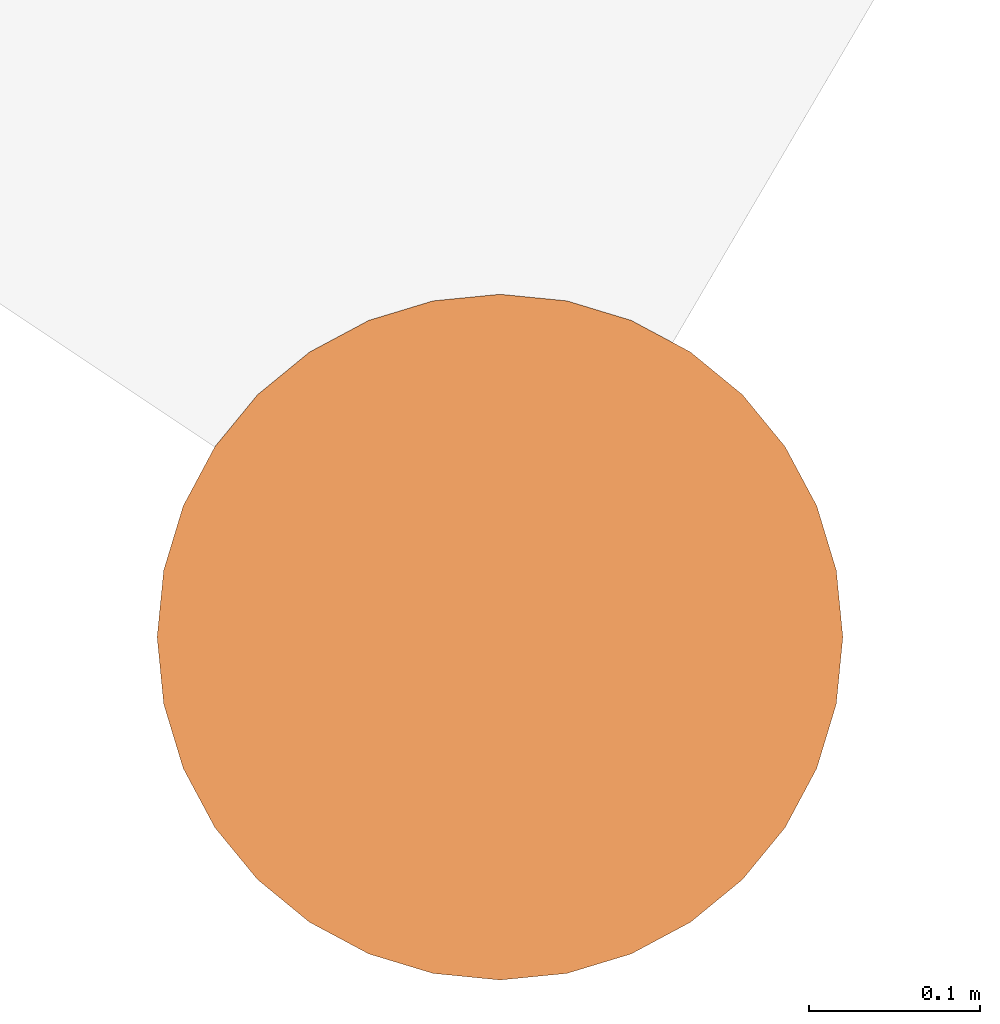
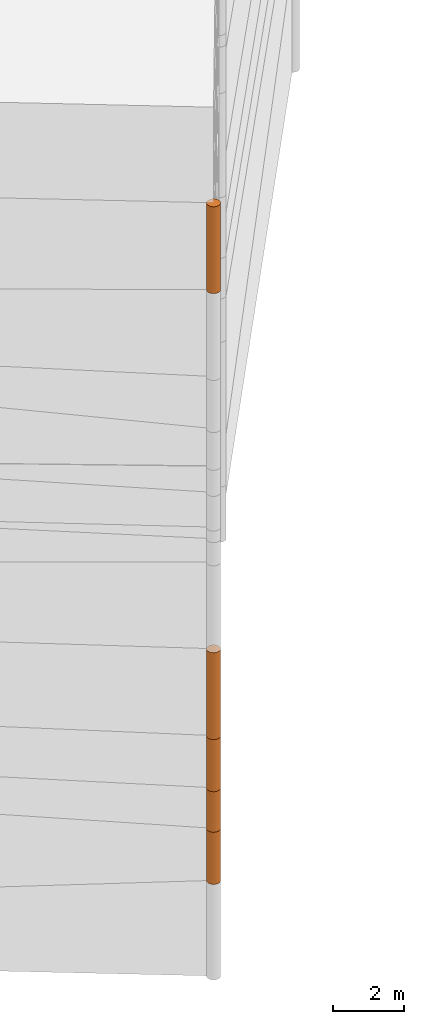
# One storey, part 1 of 24: 5 geographic elements.
"""IFC4 building model written with IfcOpenShell, lengths in metres."""

from ifc_helpers import new_model, entity, si_unit, converted_unit, frame, origin_with_axes, origin_2d_with_axis, place, context, subcontext, project, spatial, polygons, element, save


model = new_model("IFC4")

# Units and contexts
model_context = context("Model", 3, precision=1e-05, world=origin_with_axes())
plan_context = context("Plan", 2, precision=1e-05, world=origin_2d_with_axis())
body_context = subcontext(model_context, "Body", "Model", "MODEL_VIEW")
ifc_project = project(units=[converted_unit("PLANEANGLEUNIT", "degree", entity("IfcReal", 0.0174532925199433), si_unit("PLANEANGLEUNIT", "RADIAN"), dimensions=[0, 0, 0, 0, 0, 0, 0]), si_unit("AREAUNIT", "SQUARE_METRE"), si_unit("VOLUMEUNIT", "CUBIC_METRE"), si_unit("LENGTHUNIT", "METRE")], contexts=[model_context, plan_context])

# Site, building, storey
site_placement = place(None, origin_with_axes())
site = spatial("IfcSite", under=ifc_project, at=site_placement)
building_placement = place(site_placement, origin_with_axes())
building = spatial("IfcBuilding", under=site, at=building_placement, Name="Building")
storey_placement = place(building_placement, origin_with_axes())
storey = spatial("IfcBuildingStorey", under=building, at=storey_placement, Name="Storey")

# Geographic elements
geographic_element_1_placement = place(storey_placement, frame((0.0, 0.0, 14.100001335144), z_axis=(0.0, 0.0, 1.0), x_axis=(1.0, 0.0, 0.0)))
element("IfcGeographicElement", 1, at=geographic_element_1_placement, inside=storey, PredefinedType="NOTDEFINED", context=body_context, shape_type="Tessellation", body=[
    polygons([(0.0, 0.0, -1.49999988079071), (0.0390180610120296, 0.196157038211823, -1.49999988079071), (0.0, 0.199999988079071, -1.49999988079071), (0.0, 0.0, 1.49999988079071), (0.0, 0.199999988079071, 1.49999988079071), (0.0390180610120296, 0.196157038211823, 1.49999988079071), (0.0765366926789284, 0.18477588891983, -1.49999988079071), (0.0765366926789284, 0.18477588891983, 1.49999988079071), (0.111114047467709, 0.166293919086456, -1.49999988079071), (0.111114047467709, 0.166293919086456, 1.49999988079071), (0.141421362757683, 0.141421362757683, -1.49999988079071), (0.141421362757683, 0.141421362757683, 1.49999988079071), (0.166293919086456, 0.111114047467709, -1.49999988079071), (0.166293919086456, 0.111114047467709, 1.49999988079071), (0.18477588891983, 0.0765366926789284, -1.49999988079071), (0.18477588891983, 0.0765366926789284, 1.49999988079071), (0.196157038211823, 0.0390180610120296, -1.49999988079071), (0.196157038211823, 0.0390180610120296, 1.49999988079071), (0.199999988079071, 0.0, -1.49999988079071), (0.199999988079071, 0.0, 1.49999988079071), (0.196157038211823, -0.0390180610120296, -1.49999988079071), (0.196157038211823, -0.0390180610120296, 1.49999988079071), (0.18477588891983, -0.0765366926789284, -1.49999988079071), (0.18477588891983, -0.0765366926789284, 1.49999988079071), (0.166293919086456, -0.111114047467709, -1.49999988079071), (0.166293919086456, -0.111114047467709, 1.49999988079071), (0.141421362757683, -0.141421362757683, -1.49999988079071), (0.141421362757683, -0.141421362757683, 1.49999988079071), (0.111114047467709, -0.166293919086456, -1.49999988079071), (0.111114047467709, -0.166293919086456, 1.49999988079071), (0.0765366926789284, -0.18477588891983, -1.49999988079071), (0.0765366926789284, -0.18477588891983, 1.49999988079071), (0.0390180610120296, -0.196157038211823, -1.49999988079071), (0.0390180610120296, -0.196157038211823, 1.49999988079071), (0.0, -0.199999988079071, -1.49999988079071), (0.0, -0.199999988079071, 1.49999988079071), (-0.0390180610120296, -0.196157038211823, -1.49999988079071), (-0.0390180610120296, -0.196157038211823, 1.49999988079071), (-0.0765366926789284, -0.18477588891983, -1.49999988079071), (-0.0765366926789284, -0.18477588891983, 1.49999988079071), (-0.111114047467709, -0.166293919086456, -1.49999988079071), (-0.111114047467709, -0.166293919086456, 1.49999988079071), (-0.141421362757683, -0.141421362757683, -1.49999988079071), (-0.141421362757683, -0.141421362757683, 1.49999988079071), (-0.166293919086456, -0.111114047467709, -1.49999988079071), (-0.166293919086456, -0.111114047467709, 1.49999988079071), (-0.18477588891983, -0.0765366926789284, -1.49999988079071), (-0.18477588891983, -0.0765366926789284, 1.49999988079071), (-0.196157038211823, -0.0390180610120296, -1.49999988079071), (-0.196157038211823, -0.0390180610120296, 1.49999988079071), (-0.199999988079071, 0.0, -1.49999988079071), (-0.199999988079071, 0.0, 1.49999988079071), (-0.196157038211823, 0.0390180610120296, -1.49999988079071), (-0.196157038211823, 0.0390180610120296, 1.49999988079071), (-0.18477588891983, 0.0765366926789284, -1.49999988079071), (-0.18477588891983, 0.0765366926789284, 1.49999988079071), (-0.166293919086456, 0.111114047467709, -1.49999988079071), (-0.166293919086456, 0.111114047467709, 1.49999988079071), (-0.141421362757683, 0.141421362757683, -1.49999988079071), (-0.141421362757683, 0.141421362757683, 1.49999988079071), (-0.111114047467709, 0.166293919086456, -1.49999988079071), (-0.111114047467709, 0.166293919086456, 1.49999988079071), (-0.0765366926789284, 0.18477588891983, -1.49999988079071), (-0.0765366926789284, 0.18477588891983, 1.49999988079071), (-0.0390180610120296, 0.196157038211823, -1.49999988079071), (-0.0390180610120296, 0.196157038211823, 1.49999988079071)], [[[3, 2, 1]], [[6, 5, 4]], [[28, 30, 29, 27]], [[2, 7, 1]], [[8, 6, 4]], [[64, 66, 65, 63]], [[7, 9, 1]], [[10, 8, 4]], [[9, 11, 1]], [[12, 10, 4]], [[6, 8, 7, 2]], [[1, 11, 13]], [[12, 4, 14]], [[66, 5, 3, 65]], [[1, 13, 15]], [[14, 4, 16]], [[12, 14, 13, 11]], [[1, 15, 17]], [[16, 4, 18]], [[14, 16, 15, 13]], [[1, 17, 19]], [[4, 20, 18]], [[16, 18, 17, 15]], [[1, 19, 21]], [[4, 22, 20]], [[18, 20, 19, 17]], [[1, 21, 23]], [[22, 4, 24]], [[20, 22, 21, 19]], [[1, 23, 25]], [[4, 26, 24]], [[22, 24, 23, 21]], [[27, 1, 25]], [[4, 28, 26]], [[24, 26, 25, 23]], [[1, 27, 29]], [[28, 4, 30]], [[26, 28, 27, 25]], [[1, 29, 31]], [[4, 32, 30]], [[5, 6, 2, 3]], [[1, 31, 33]], [[4, 34, 32]], [[30, 32, 31, 29]], [[1, 33, 35]], [[4, 36, 34]], [[8, 10, 9, 7]], [[1, 35, 37]], [[4, 38, 36]], [[32, 34, 33, 31]], [[1, 37, 39]], [[4, 40, 38]], [[36, 38, 37, 35]], [[1, 39, 41]], [[4, 42, 40]], [[38, 40, 39, 37]], [[43, 1, 41]], [[4, 44, 42]], [[40, 42, 41, 39]], [[43, 45, 1]], [[46, 44, 4]], [[42, 44, 43, 41]], [[45, 47, 1]], [[4, 48, 46]], [[44, 46, 45, 43]], [[49, 1, 47]], [[4, 50, 48]], [[46, 48, 47, 45]], [[49, 51, 1]], [[52, 50, 4]], [[48, 50, 49, 47]], [[51, 53, 1]], [[54, 52, 4]], [[50, 52, 51, 49]], [[55, 1, 53]], [[4, 56, 54]], [[52, 54, 53, 51]], [[57, 1, 55]], [[58, 56, 4]], [[54, 56, 55, 53]], [[57, 59, 1]], [[60, 58, 4]], [[56, 58, 57, 55]], [[59, 61, 1]], [[62, 60, 4]], [[58, 60, 59, 57]], [[61, 63, 1]], [[64, 62, 4]], [[60, 62, 61, 59]], [[63, 65, 1]], [[66, 64, 4]], [[62, 64, 63, 61]], [[65, 3, 1]], [[5, 66, 4]], [[34, 36, 35, 33]], [[10, 12, 11, 9]]]),
])
geographic_element_2_placement = place(storey_placement, frame((0.0, 0.0, -6.89999723434448), z_axis=(0.0, 0.0, 1.0), x_axis=(1.0, 0.0, 0.0)))
element("IfcGeographicElement", 2, at=geographic_element_2_placement, inside=storey, PredefinedType="NOTDEFINED", context=body_context, shape_type="Tessellation", body=[
    polygons([(0.0, 0.0, -0.899999916553497), (0.0390180610120296, 0.196157038211823, -0.899999916553497), (0.0, 0.199999988079071, -0.899999916553497), (0.0, 0.0, 0.899999916553497), (0.0, 0.199999988079071, 0.899999916553497), (0.0390180610120296, 0.196157038211823, 0.899999916553497), (0.0765366926789284, 0.18477588891983, -0.899999916553497), (0.0765366926789284, 0.18477588891983, 0.899999916553497), (0.111114047467709, 0.166293919086456, -0.899999916553497), (0.111114047467709, 0.166293919086456, 0.899999916553497), (0.141421362757683, 0.141421362757683, -0.899999916553497), (0.141421362757683, 0.141421362757683, 0.899999916553497), (0.166293919086456, 0.111114047467709, -0.899999916553497), (0.166293919086456, 0.111114047467709, 0.899999916553497), (0.18477588891983, 0.0765366926789284, -0.899999916553497), (0.18477588891983, 0.0765366926789284, 0.899999916553497), (0.196157038211823, 0.0390180610120296, -0.899999916553497), (0.196157038211823, 0.0390180610120296, 0.899999916553497), (0.199999988079071, 0.0, -0.899999916553497), (0.199999988079071, 0.0, 0.899999916553497), (0.196157038211823, -0.0390180610120296, -0.899999916553497), (0.196157038211823, -0.0390180610120296, 0.899999916553497), (0.18477588891983, -0.0765366926789284, -0.899999916553497), (0.18477588891983, -0.0765366926789284, 0.899999916553497), (0.166293919086456, -0.111114047467709, -0.899999916553497), (0.166293919086456, -0.111114047467709, 0.899999916553497), (0.141421362757683, -0.141421362757683, -0.899999916553497), (0.141421362757683, -0.141421362757683, 0.899999916553497), (0.111114047467709, -0.166293919086456, -0.899999916553497), (0.111114047467709, -0.166293919086456, 0.899999916553497), (0.0765366926789284, -0.18477588891983, -0.899999916553497), (0.0765366926789284, -0.18477588891983, 0.899999916553497), (0.0390180610120296, -0.196157038211823, -0.899999916553497), (0.0390180610120296, -0.196157038211823, 0.899999916553497), (0.0, -0.199999988079071, -0.899999916553497), (0.0, -0.199999988079071, 0.899999916553497), (-0.0390180610120296, -0.196157038211823, -0.899999916553497), (-0.0390180610120296, -0.196157038211823, 0.899999916553497), (-0.0765366926789284, -0.18477588891983, -0.899999916553497), (-0.0765366926789284, -0.18477588891983, 0.899999916553497), (-0.111114047467709, -0.166293919086456, -0.899999916553497), (-0.111114047467709, -0.166293919086456, 0.899999916553497), (-0.141421362757683, -0.141421362757683, -0.899999916553497), (-0.141421362757683, -0.141421362757683, 0.899999916553497), (-0.166293919086456, -0.111114047467709, -0.899999916553497), (-0.166293919086456, -0.111114047467709, 0.899999916553497), (-0.18477588891983, -0.0765366926789284, -0.899999916553497), (-0.18477588891983, -0.0765366926789284, 0.899999916553497), (-0.196157038211823, -0.0390180610120296, -0.899999916553497), (-0.196157038211823, -0.0390180610120296, 0.899999916553497), (-0.199999988079071, 0.0, -0.899999916553497), (-0.199999988079071, 0.0, 0.899999916553497), (-0.196157038211823, 0.0390180610120296, -0.899999916553497), (-0.196157038211823, 0.0390180610120296, 0.899999916553497), (-0.18477588891983, 0.0765366926789284, -0.899999916553497), (-0.18477588891983, 0.0765366926789284, 0.899999916553497), (-0.166293919086456, 0.111114047467709, -0.899999916553497), (-0.166293919086456, 0.111114047467709, 0.899999916553497), (-0.141421362757683, 0.141421362757683, -0.899999916553497), (-0.141421362757683, 0.141421362757683, 0.899999916553497), (-0.111114047467709, 0.166293919086456, -0.899999916553497), (-0.111114047467709, 0.166293919086456, 0.899999916553497), (-0.0765366926789284, 0.18477588891983, -0.899999916553497), (-0.0765366926789284, 0.18477588891983, 0.899999916553497), (-0.0390180610120296, 0.196157038211823, -0.899999916553497), (-0.0390180610120296, 0.196157038211823, 0.899999916553497)], [[[3, 2, 1]], [[6, 5, 4]], [[32, 34, 33, 31]], [[2, 7, 1]], [[8, 6, 4]], [[64, 66, 65, 63]], [[7, 9, 1]], [[10, 8, 4]], [[9, 11, 1]], [[12, 10, 4]], [[40, 42, 41, 39]], [[1, 11, 13]], [[12, 4, 14]], [[10, 12, 11, 9]], [[1, 13, 15]], [[4, 16, 14]], [[12, 14, 13, 11]], [[1, 15, 17]], [[16, 4, 18]], [[18, 20, 19, 17]], [[1, 17, 19]], [[4, 20, 18]], [[20, 22, 21, 19]], [[1, 19, 21]], [[4, 22, 20]], [[22, 24, 23, 21]], [[1, 21, 23]], [[22, 4, 24]], [[54, 56, 55, 53]], [[1, 23, 25]], [[4, 26, 24]], [[56, 58, 57, 55]], [[1, 25, 27]], [[4, 28, 26]], [[24, 26, 25, 23]], [[1, 27, 29]], [[28, 4, 30]], [[26, 28, 27, 25]], [[1, 29, 31]], [[4, 32, 30]], [[46, 48, 47, 45]], [[1, 31, 33]], [[4, 34, 32]], [[36, 38, 37, 35]], [[1, 33, 35]], [[4, 36, 34]], [[42, 44, 43, 41]], [[1, 35, 37]], [[4, 38, 36]], [[38, 40, 39, 37]], [[1, 37, 39]], [[4, 40, 38]], [[34, 36, 35, 33]], [[1, 39, 41]], [[4, 42, 40]], [[8, 10, 9, 7]], [[43, 1, 41]], [[4, 44, 42]], [[44, 46, 45, 43]], [[43, 45, 1]], [[4, 46, 44]], [[30, 32, 31, 29]], [[45, 47, 1]], [[48, 46, 4]], [[28, 30, 29, 27]], [[49, 1, 47]], [[4, 50, 48]], [[5, 6, 2, 3]], [[49, 51, 1]], [[52, 50, 4]], [[48, 50, 49, 47]], [[51, 53, 1]], [[54, 52, 4]], [[50, 52, 51, 49]], [[55, 1, 53]], [[4, 56, 54]], [[52, 54, 53, 51]], [[55, 57, 1]], [[58, 56, 4]], [[58, 60, 59, 57]], [[59, 1, 57]], [[60, 58, 4]], [[60, 62, 61, 59]], [[59, 61, 1]], [[62, 60, 4]], [[62, 64, 63, 61]], [[61, 63, 1]], [[64, 62, 4]], [[14, 16, 15, 13]], [[63, 65, 1]], [[66, 64, 4]], [[16, 18, 17, 15]], [[65, 3, 1]], [[5, 66, 4]], [[6, 8, 7, 2]], [[66, 5, 3, 65]]]),
])
geographic_element_3_placement = place(storey_placement, frame((0.0, 0.0, -5.29999732971191), z_axis=(0.0, 0.0, 1.0), x_axis=(1.0, 0.0, 0.0)))
element("IfcGeographicElement", 3, at=geographic_element_3_placement, inside=storey, PredefinedType="NOTDEFINED", context=body_context, shape_type="Tessellation", body=[
    polygons([(0.0, 0.0, -0.699999928474426), (0.0390180610120296, 0.196157038211823, -0.699999928474426), (0.0, 0.199999988079071, -0.699999928474426), (0.0, 0.0, 0.699999928474426), (0.0, 0.199999988079071, 0.699999928474426), (0.0390180610120296, 0.196157038211823, 0.699999928474426), (0.0765366926789284, 0.18477588891983, -0.699999928474426), (0.0765366926789284, 0.18477588891983, 0.699999928474426), (0.111114047467709, 0.166293919086456, -0.699999928474426), (0.111114047467709, 0.166293919086456, 0.699999928474426), (0.141421362757683, 0.141421362757683, -0.699999928474426), (0.141421362757683, 0.141421362757683, 0.699999928474426), (0.166293919086456, 0.111114047467709, -0.699999928474426), (0.166293919086456, 0.111114047467709, 0.699999928474426), (0.18477588891983, 0.0765366926789284, -0.699999928474426), (0.18477588891983, 0.0765366926789284, 0.699999928474426), (0.196157038211823, 0.0390180610120296, -0.699999928474426), (0.196157038211823, 0.0390180610120296, 0.699999928474426), (0.199999988079071, 0.0, -0.699999928474426), (0.199999988079071, 0.0, 0.699999928474426), (0.196157038211823, -0.0390180610120296, -0.699999928474426), (0.196157038211823, -0.0390180610120296, 0.699999928474426), (0.18477588891983, -0.0765366926789284, -0.699999928474426), (0.18477588891983, -0.0765366926789284, 0.699999928474426), (0.166293919086456, -0.111114047467709, -0.699999928474426), (0.166293919086456, -0.111114047467709, 0.699999928474426), (0.141421362757683, -0.141421362757683, -0.699999928474426), (0.141421362757683, -0.141421362757683, 0.699999928474426), (0.111114047467709, -0.166293919086456, -0.699999928474426), (0.111114047467709, -0.166293919086456, 0.699999928474426), (0.0765366926789284, -0.18477588891983, -0.699999928474426), (0.0765366926789284, -0.18477588891983, 0.699999928474426), (0.0390180610120296, -0.196157038211823, -0.699999928474426), (0.0390180610120296, -0.196157038211823, 0.699999928474426), (0.0, -0.199999988079071, -0.699999928474426), (0.0, -0.199999988079071, 0.699999928474426), (-0.0390180610120296, -0.196157038211823, -0.699999928474426), (-0.0390180610120296, -0.196157038211823, 0.699999928474426), (-0.0765366926789284, -0.18477588891983, -0.699999928474426), (-0.0765366926789284, -0.18477588891983, 0.699999928474426), (-0.111114047467709, -0.166293919086456, -0.699999928474426), (-0.111114047467709, -0.166293919086456, 0.699999928474426), (-0.141421362757683, -0.141421362757683, -0.699999928474426), (-0.141421362757683, -0.141421362757683, 0.699999928474426), (-0.166293919086456, -0.111114047467709, -0.699999928474426), (-0.166293919086456, -0.111114047467709, 0.699999928474426), (-0.18477588891983, -0.0765366926789284, -0.699999928474426), (-0.18477588891983, -0.0765366926789284, 0.699999928474426), (-0.196157038211823, -0.0390180610120296, -0.699999928474426), (-0.196157038211823, -0.0390180610120296, 0.699999928474426), (-0.199999988079071, 0.0, -0.699999928474426), (-0.199999988079071, 0.0, 0.699999928474426), (-0.196157038211823, 0.0390180610120296, -0.699999928474426), (-0.196157038211823, 0.0390180610120296, 0.699999928474426), (-0.18477588891983, 0.0765366926789284, -0.699999928474426), (-0.18477588891983, 0.0765366926789284, 0.699999928474426), (-0.166293919086456, 0.111114047467709, -0.699999928474426), (-0.166293919086456, 0.111114047467709, 0.699999928474426), (-0.141421362757683, 0.141421362757683, -0.699999928474426), (-0.141421362757683, 0.141421362757683, 0.699999928474426), (-0.111114047467709, 0.166293919086456, -0.699999928474426), (-0.111114047467709, 0.166293919086456, 0.699999928474426), (-0.0765366926789284, 0.18477588891983, -0.699999928474426), (-0.0765366926789284, 0.18477588891983, 0.699999928474426), (-0.0390180610120296, 0.196157038211823, -0.699999928474426), (-0.0390180610120296, 0.196157038211823, 0.699999928474426)], [[[3, 2, 1]], [[6, 5, 4]], [[28, 30, 29, 27]], [[2, 7, 1]], [[8, 6, 4]], [[36, 38, 37, 35]], [[7, 9, 1]], [[10, 8, 4]], [[56, 58, 57, 55]], [[9, 11, 1]], [[12, 10, 4]], [[58, 60, 59, 57]], [[11, 13, 1]], [[12, 4, 14]], [[54, 56, 55, 53]], [[1, 13, 15]], [[4, 16, 14]], [[10, 12, 11, 9]], [[1, 15, 17]], [[4, 18, 16]], [[60, 62, 61, 59]], [[1, 17, 19]], [[4, 20, 18]], [[16, 18, 17, 15]], [[1, 19, 21]], [[4, 22, 20]], [[18, 20, 19, 17]], [[1, 21, 23]], [[4, 24, 22]], [[20, 22, 21, 19]], [[1, 23, 25]], [[4, 26, 24]], [[22, 24, 23, 21]], [[27, 1, 25]], [[26, 4, 28]], [[24, 26, 25, 23]], [[1, 27, 29]], [[28, 4, 30]], [[62, 64, 63, 61]], [[1, 29, 31]], [[4, 32, 30]], [[64, 66, 65, 63]], [[1, 31, 33]], [[4, 34, 32]], [[30, 32, 31, 29]], [[1, 33, 35]], [[4, 36, 34]], [[8, 10, 9, 7]], [[1, 35, 37]], [[4, 38, 36]], [[32, 34, 33, 31]], [[1, 37, 39]], [[4, 40, 38]], [[6, 8, 7, 2]], [[1, 39, 41]], [[4, 42, 40]], [[38, 40, 39, 37]], [[43, 1, 41]], [[4, 44, 42]], [[40, 42, 41, 39]], [[45, 1, 43]], [[46, 44, 4]], [[42, 44, 43, 41]], [[45, 47, 1]], [[48, 46, 4]], [[44, 46, 45, 43]], [[47, 49, 1]], [[50, 48, 4]], [[46, 48, 47, 45]], [[49, 51, 1]], [[52, 50, 4]], [[48, 50, 49, 47]], [[51, 53, 1]], [[54, 52, 4]], [[66, 5, 3, 65]], [[53, 55, 1]], [[56, 54, 4]], [[52, 54, 53, 51]], [[55, 57, 1]], [[58, 56, 4]], [[57, 59, 1]], [[60, 58, 4]], [[34, 36, 35, 33]], [[59, 61, 1]], [[62, 60, 4]], [[14, 16, 15, 13]], [[61, 63, 1]], [[64, 62, 4]], [[26, 28, 27, 25]], [[63, 65, 1]], [[66, 64, 4]], [[5, 6, 2, 3]], [[65, 3, 1]], [[5, 66, 4]], [[50, 52, 51, 49]], [[12, 14, 13, 11]]]),
])
geographic_element_4_placement = place(storey_placement, frame((0.0, 0.0, -3.69999742507935), z_axis=(0.0, 0.0, 1.0), x_axis=(1.0, 0.0, 0.0)))
element("IfcGeographicElement", 4, at=geographic_element_4_placement, inside=storey, PredefinedType="NOTDEFINED", context=body_context, shape_type="Tessellation", body=[
    polygons([(0.0, 0.0, -0.899999916553497), (0.0390180610120296, 0.196157038211823, -0.899999916553497), (0.0, 0.199999988079071, -0.899999916553497), (0.0, 0.0, 0.899999916553497), (0.0, 0.199999988079071, 0.899999916553497), (0.0390180610120296, 0.196157038211823, 0.899999916553497), (0.0765366926789284, 0.18477588891983, -0.899999916553497), (0.0765366926789284, 0.18477588891983, 0.899999916553497), (0.111114047467709, 0.166293919086456, -0.899999916553497), (0.111114047467709, 0.166293919086456, 0.899999916553497), (0.141421362757683, 0.141421362757683, -0.899999916553497), (0.141421362757683, 0.141421362757683, 0.899999916553497), (0.166293919086456, 0.111114047467709, -0.899999916553497), (0.166293919086456, 0.111114047467709, 0.899999916553497), (0.18477588891983, 0.0765366926789284, -0.899999916553497), (0.18477588891983, 0.0765366926789284, 0.899999916553497), (0.196157038211823, 0.0390180610120296, -0.899999916553497), (0.196157038211823, 0.0390180610120296, 0.899999916553497), (0.199999988079071, 0.0, -0.899999916553497), (0.199999988079071, 0.0, 0.899999916553497), (0.196157038211823, -0.0390180610120296, -0.899999916553497), (0.196157038211823, -0.0390180610120296, 0.899999916553497), (0.18477588891983, -0.0765366926789284, -0.899999916553497), (0.18477588891983, -0.0765366926789284, 0.899999916553497), (0.166293919086456, -0.111114047467709, -0.899999916553497), (0.166293919086456, -0.111114047467709, 0.899999916553497), (0.141421362757683, -0.141421362757683, -0.899999916553497), (0.141421362757683, -0.141421362757683, 0.899999916553497), (0.111114047467709, -0.166293919086456, -0.899999916553497), (0.111114047467709, -0.166293919086456, 0.899999916553497), (0.0765366926789284, -0.18477588891983, -0.899999916553497), (0.0765366926789284, -0.18477588891983, 0.899999916553497), (0.0390180610120296, -0.196157038211823, -0.899999916553497), (0.0390180610120296, -0.196157038211823, 0.899999916553497), (0.0, -0.199999988079071, -0.899999916553497), (0.0, -0.199999988079071, 0.899999916553497), (-0.0390180610120296, -0.196157038211823, -0.899999916553497), (-0.0390180610120296, -0.196157038211823, 0.899999916553497), (-0.0765366926789284, -0.18477588891983, -0.899999916553497), (-0.0765366926789284, -0.18477588891983, 0.899999916553497), (-0.111114047467709, -0.166293919086456, -0.899999916553497), (-0.111114047467709, -0.166293919086456, 0.899999916553497), (-0.141421362757683, -0.141421362757683, -0.899999916553497), (-0.141421362757683, -0.141421362757683, 0.899999916553497), (-0.166293919086456, -0.111114047467709, -0.899999916553497), (-0.166293919086456, -0.111114047467709, 0.899999916553497), (-0.18477588891983, -0.0765366926789284, -0.899999916553497), (-0.18477588891983, -0.0765366926789284, 0.899999916553497), (-0.196157038211823, -0.0390180610120296, -0.899999916553497), (-0.196157038211823, -0.0390180610120296, 0.899999916553497), (-0.199999988079071, 0.0, -0.899999916553497), (-0.199999988079071, 0.0, 0.899999916553497), (-0.196157038211823, 0.0390180610120296, -0.899999916553497), (-0.196157038211823, 0.0390180610120296, 0.899999916553497), (-0.18477588891983, 0.0765366926789284, -0.899999916553497), (-0.18477588891983, 0.0765366926789284, 0.899999916553497), (-0.166293919086456, 0.111114047467709, -0.899999916553497), (-0.166293919086456, 0.111114047467709, 0.899999916553497), (-0.141421362757683, 0.141421362757683, -0.899999916553497), (-0.141421362757683, 0.141421362757683, 0.899999916553497), (-0.111114047467709, 0.166293919086456, -0.899999916553497), (-0.111114047467709, 0.166293919086456, 0.899999916553497), (-0.0765366926789284, 0.18477588891983, -0.899999916553497), (-0.0765366926789284, 0.18477588891983, 0.899999916553497), (-0.0390180610120296, 0.196157038211823, -0.899999916553497), (-0.0390180610120296, 0.196157038211823, 0.899999916553497)], [[[3, 2, 1]], [[6, 5, 4]], [[32, 34, 33, 31]], [[2, 7, 1]], [[8, 6, 4]], [[64, 66, 65, 63]], [[7, 9, 1]], [[10, 8, 4]], [[9, 11, 1]], [[12, 10, 4]], [[40, 42, 41, 39]], [[1, 11, 13]], [[12, 4, 14]], [[10, 12, 11, 9]], [[1, 13, 15]], [[4, 16, 14]], [[12, 14, 13, 11]], [[1, 15, 17]], [[16, 4, 18]], [[18, 20, 19, 17]], [[1, 17, 19]], [[4, 20, 18]], [[20, 22, 21, 19]], [[1, 19, 21]], [[4, 22, 20]], [[22, 24, 23, 21]], [[1, 21, 23]], [[22, 4, 24]], [[54, 56, 55, 53]], [[1, 23, 25]], [[4, 26, 24]], [[56, 58, 57, 55]], [[1, 25, 27]], [[4, 28, 26]], [[24, 26, 25, 23]], [[1, 27, 29]], [[28, 4, 30]], [[26, 28, 27, 25]], [[1, 29, 31]], [[4, 32, 30]], [[46, 48, 47, 45]], [[1, 31, 33]], [[4, 34, 32]], [[36, 38, 37, 35]], [[1, 33, 35]], [[4, 36, 34]], [[42, 44, 43, 41]], [[1, 35, 37]], [[4, 38, 36]], [[38, 40, 39, 37]], [[1, 37, 39]], [[4, 40, 38]], [[34, 36, 35, 33]], [[1, 39, 41]], [[4, 42, 40]], [[8, 10, 9, 7]], [[43, 1, 41]], [[4, 44, 42]], [[44, 46, 45, 43]], [[43, 45, 1]], [[4, 46, 44]], [[30, 32, 31, 29]], [[45, 47, 1]], [[48, 46, 4]], [[28, 30, 29, 27]], [[49, 1, 47]], [[4, 50, 48]], [[5, 6, 2, 3]], [[49, 51, 1]], [[52, 50, 4]], [[48, 50, 49, 47]], [[51, 53, 1]], [[54, 52, 4]], [[50, 52, 51, 49]], [[55, 1, 53]], [[4, 56, 54]], [[52, 54, 53, 51]], [[55, 57, 1]], [[58, 56, 4]], [[58, 60, 59, 57]], [[59, 1, 57]], [[60, 58, 4]], [[60, 62, 61, 59]], [[59, 61, 1]], [[62, 60, 4]], [[62, 64, 63, 61]], [[61, 63, 1]], [[64, 62, 4]], [[14, 16, 15, 13]], [[63, 65, 1]], [[66, 64, 4]], [[16, 18, 17, 15]], [[65, 3, 1]], [[5, 66, 4]], [[6, 8, 7, 2]], [[66, 5, 3, 65]]]),
])
geographic_element_5_placement = place(storey_placement, frame((0.0, 0.0, -1.2999974489212), z_axis=(0.0, 0.0, 1.0), x_axis=(1.0, 0.0, 0.0)))
element("IfcGeographicElement", 5, at=geographic_element_5_placement, inside=storey, PredefinedType="NOTDEFINED", context=body_context, shape_type="Tessellation", body=[
    polygons([(0.0, 0.0, -1.49999988079071), (0.0390180610120296, 0.196157038211823, -1.49999988079071), (0.0, 0.199999988079071, -1.49999988079071), (0.0, 0.0, 1.49999988079071), (0.0, 0.199999988079071, 1.49999988079071), (0.0390180610120296, 0.196157038211823, 1.49999988079071), (0.0765366926789284, 0.18477588891983, -1.49999988079071), (0.0765366926789284, 0.18477588891983, 1.49999988079071), (0.111114047467709, 0.166293919086456, -1.49999988079071), (0.111114047467709, 0.166293919086456, 1.49999988079071), (0.141421362757683, 0.141421362757683, -1.49999988079071), (0.141421362757683, 0.141421362757683, 1.49999988079071), (0.166293919086456, 0.111114047467709, -1.49999988079071), (0.166293919086456, 0.111114047467709, 1.49999988079071), (0.18477588891983, 0.0765366926789284, -1.49999988079071), (0.18477588891983, 0.0765366926789284, 1.49999988079071), (0.196157038211823, 0.0390180610120296, -1.49999988079071), (0.196157038211823, 0.0390180610120296, 1.49999988079071), (0.199999988079071, 0.0, -1.49999988079071), (0.199999988079071, 0.0, 1.49999988079071), (0.196157038211823, -0.0390180610120296, -1.49999988079071), (0.196157038211823, -0.0390180610120296, 1.49999988079071), (0.18477588891983, -0.0765366926789284, -1.49999988079071), (0.18477588891983, -0.0765366926789284, 1.49999988079071), (0.166293919086456, -0.111114047467709, -1.49999988079071), (0.166293919086456, -0.111114047467709, 1.49999988079071), (0.141421362757683, -0.141421362757683, -1.49999988079071), (0.141421362757683, -0.141421362757683, 1.49999988079071), (0.111114047467709, -0.166293919086456, -1.49999988079071), (0.111114047467709, -0.166293919086456, 1.49999988079071), (0.0765366926789284, -0.18477588891983, -1.49999988079071), (0.0765366926789284, -0.18477588891983, 1.49999988079071), (0.0390180610120296, -0.196157038211823, -1.49999988079071), (0.0390180610120296, -0.196157038211823, 1.49999988079071), (0.0, -0.199999988079071, -1.49999988079071), (0.0, -0.199999988079071, 1.49999988079071), (-0.0390180610120296, -0.196157038211823, -1.49999988079071), (-0.0390180610120296, -0.196157038211823, 1.49999988079071), (-0.0765366926789284, -0.18477588891983, -1.49999988079071), (-0.0765366926789284, -0.18477588891983, 1.49999988079071), (-0.111114047467709, -0.166293919086456, -1.49999988079071), (-0.111114047467709, -0.166293919086456, 1.49999988079071), (-0.141421362757683, -0.141421362757683, -1.49999988079071), (-0.141421362757683, -0.141421362757683, 1.49999988079071), (-0.166293919086456, -0.111114047467709, -1.49999988079071), (-0.166293919086456, -0.111114047467709, 1.49999988079071), (-0.18477588891983, -0.0765366926789284, -1.49999988079071), (-0.18477588891983, -0.0765366926789284, 1.49999988079071), (-0.196157038211823, -0.0390180610120296, -1.49999988079071), (-0.196157038211823, -0.0390180610120296, 1.49999988079071), (-0.199999988079071, 0.0, -1.49999988079071), (-0.199999988079071, 0.0, 1.49999988079071), (-0.196157038211823, 0.0390180610120296, -1.49999988079071), (-0.196157038211823, 0.0390180610120296, 1.49999988079071), (-0.18477588891983, 0.0765366926789284, -1.49999988079071), (-0.18477588891983, 0.0765366926789284, 1.49999988079071), (-0.166293919086456, 0.111114047467709, -1.49999988079071), (-0.166293919086456, 0.111114047467709, 1.49999988079071), (-0.141421362757683, 0.141421362757683, -1.49999988079071), (-0.141421362757683, 0.141421362757683, 1.49999988079071), (-0.111114047467709, 0.166293919086456, -1.49999988079071), (-0.111114047467709, 0.166293919086456, 1.49999988079071), (-0.0765366926789284, 0.18477588891983, -1.49999988079071), (-0.0765366926789284, 0.18477588891983, 1.49999988079071), (-0.0390180610120296, 0.196157038211823, -1.49999988079071), (-0.0390180610120296, 0.196157038211823, 1.49999988079071)], [[[3, 2, 1]], [[6, 5, 4]], [[28, 30, 29, 27]], [[2, 7, 1]], [[8, 6, 4]], [[64, 66, 65, 63]], [[7, 9, 1]], [[10, 8, 4]], [[9, 11, 1]], [[12, 10, 4]], [[6, 8, 7, 2]], [[1, 11, 13]], [[12, 4, 14]], [[66, 5, 3, 65]], [[1, 13, 15]], [[14, 4, 16]], [[12, 14, 13, 11]], [[1, 15, 17]], [[16, 4, 18]], [[14, 16, 15, 13]], [[1, 17, 19]], [[4, 20, 18]], [[16, 18, 17, 15]], [[1, 19, 21]], [[4, 22, 20]], [[18, 20, 19, 17]], [[1, 21, 23]], [[22, 4, 24]], [[20, 22, 21, 19]], [[1, 23, 25]], [[4, 26, 24]], [[22, 24, 23, 21]], [[27, 1, 25]], [[4, 28, 26]], [[24, 26, 25, 23]], [[1, 27, 29]], [[28, 4, 30]], [[26, 28, 27, 25]], [[1, 29, 31]], [[4, 32, 30]], [[5, 6, 2, 3]], [[1, 31, 33]], [[4, 34, 32]], [[30, 32, 31, 29]], [[1, 33, 35]], [[4, 36, 34]], [[8, 10, 9, 7]], [[1, 35, 37]], [[4, 38, 36]], [[32, 34, 33, 31]], [[1, 37, 39]], [[4, 40, 38]], [[36, 38, 37, 35]], [[1, 39, 41]], [[4, 42, 40]], [[38, 40, 39, 37]], [[43, 1, 41]], [[4, 44, 42]], [[40, 42, 41, 39]], [[43, 45, 1]], [[46, 44, 4]], [[42, 44, 43, 41]], [[45, 47, 1]], [[4, 48, 46]], [[44, 46, 45, 43]], [[49, 1, 47]], [[4, 50, 48]], [[46, 48, 47, 45]], [[49, 51, 1]], [[52, 50, 4]], [[48, 50, 49, 47]], [[51, 53, 1]], [[54, 52, 4]], [[50, 52, 51, 49]], [[55, 1, 53]], [[4, 56, 54]], [[52, 54, 53, 51]], [[57, 1, 55]], [[58, 56, 4]], [[54, 56, 55, 53]], [[57, 59, 1]], [[60, 58, 4]], [[56, 58, 57, 55]], [[59, 61, 1]], [[62, 60, 4]], [[58, 60, 59, 57]], [[61, 63, 1]], [[64, 62, 4]], [[60, 62, 61, 59]], [[63, 65, 1]], [[66, 64, 4]], [[62, 64, 63, 61]], [[65, 3, 1]], [[5, 66, 4]], [[34, 36, 35, 33]], [[10, 12, 11, 9]]]),
])

save(model, "model.ifc")
